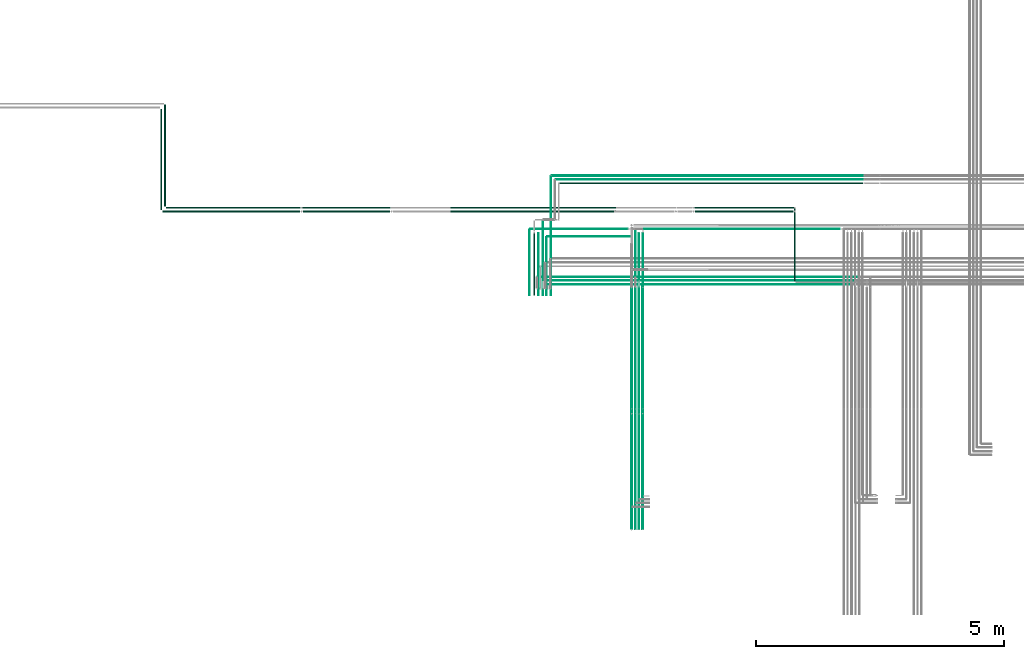
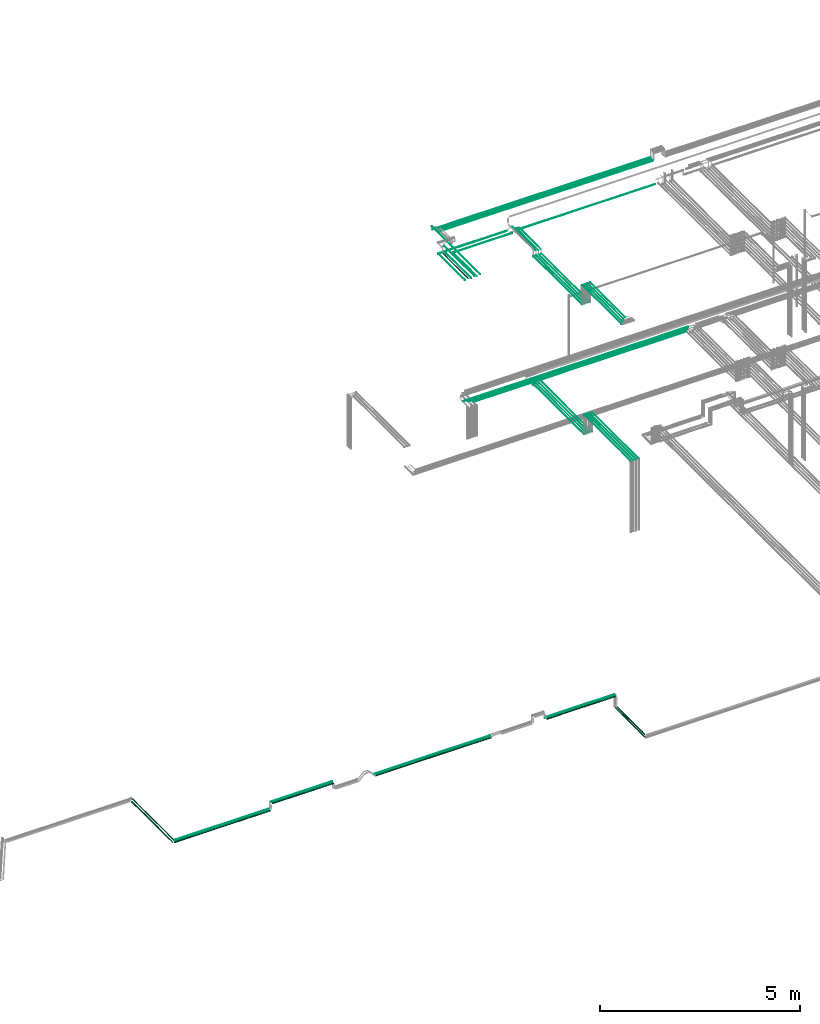
# One storey, part 3 of 331: 49 flow segments.
"""IFC2X3 building model written with IfcOpenShell, lengths in millimetres."""

from ifc_helpers import new_model, entity, si_unit, converted_unit, derived_unit, direction, frame, frame_2d, origin, origin_2d_with_axis, place, context, subcontext, project, spatial, circle, extrude, type_object, element, save


model = new_model("IFC2X3")

# Units and contexts
model_context = context("Model", 3, precision=0.01, world=origin(), true_north=direction((6.12303176911189e-17, 1.0)))
body_context = subcontext(model_context, "Body", "Model", "MODEL_VIEW")
ifc_project = project(units=[si_unit("LENGTHUNIT", "METRE", prefix="MILLI"), si_unit("AREAUNIT", "SQUARE_METRE"), si_unit("VOLUMEUNIT", "CUBIC_METRE"), converted_unit("PLANEANGLEUNIT", "DEGREE", entity("IfcRatioMeasure", 0.0174532925199433), si_unit("PLANEANGLEUNIT", "RADIAN"), dimensions=[0, 0, 0, 0, 0, 0, 0]), si_unit("MASSUNIT", "GRAM", prefix="KILO"), derived_unit("MASSDENSITYUNIT", [(si_unit("MASSUNIT", "GRAM", prefix="KILO"), 1), (si_unit("LENGTHUNIT", "METRE"), -3)]), derived_unit("MOMENTOFINERTIAUNIT", [(si_unit("LENGTHUNIT", "METRE"), 4)]), si_unit("TIMEUNIT", "SECOND"), si_unit("FREQUENCYUNIT", "HERTZ"), si_unit("THERMODYNAMICTEMPERATUREUNIT", "DEGREE_CELSIUS"), derived_unit("THERMALTRANSMITTANCEUNIT", [(si_unit("MASSUNIT", "GRAM", prefix="KILO"), 1), (si_unit("THERMODYNAMICTEMPERATUREUNIT", "KELVIN"), -1), (si_unit("TIMEUNIT", "SECOND"), -3)]), derived_unit("VOLUMETRICFLOWRATEUNIT", [(si_unit("LENGTHUNIT", "METRE"), 3), (si_unit("TIMEUNIT", "SECOND"), -1)]), derived_unit("MASSFLOWRATEUNIT", [(si_unit("MASSUNIT", "GRAM", prefix="KILO"), 1), (si_unit("TIMEUNIT", "SECOND"), -1)]), derived_unit("ROTATIONALFREQUENCYUNIT", [(si_unit("TIMEUNIT", "SECOND"), -1)]), si_unit("ELECTRICCURRENTUNIT", "AMPERE"), si_unit("ELECTRICVOLTAGEUNIT", "VOLT"), si_unit("POWERUNIT", "WATT"), si_unit("FORCEUNIT", "NEWTON", prefix="KILO"), si_unit("ILLUMINANCEUNIT", "LUX"), si_unit("LUMINOUSFLUXUNIT", "LUMEN"), si_unit("LUMINOUSINTENSITYUNIT", "CANDELA"), derived_unit("USERDEFINED", [(si_unit("MASSUNIT", "GRAM", prefix="KILO"), -1), (si_unit("LENGTHUNIT", "METRE"), -2), (si_unit("TIMEUNIT", "SECOND"), 3), (si_unit("LUMINOUSFLUXUNIT", "LUMEN"), 1)]), derived_unit("LINEARVELOCITYUNIT", [(si_unit("LENGTHUNIT", "METRE"), 1), (si_unit("TIMEUNIT", "SECOND"), -1)]), si_unit("PRESSUREUNIT", "PASCAL"), derived_unit("USERDEFINED", [(si_unit("LENGTHUNIT", "METRE"), -2), (si_unit("MASSUNIT", "GRAM", prefix="KILO"), 1), (si_unit("TIMEUNIT", "SECOND"), -2)]), derived_unit("LINEARFORCEUNIT", [(si_unit("MASSUNIT", "GRAM", prefix="KILO"), 1), (si_unit("LENGTHUNIT", "METRE"), 1), (si_unit("TIMEUNIT", "SECOND"), -2), (si_unit("LENGTHUNIT", "METRE"), -1)]), derived_unit("PLANARFORCEUNIT", [(si_unit("MASSUNIT", "GRAM", prefix="KILO"), 1), (si_unit("LENGTHUNIT", "METRE"), 1), (si_unit("TIMEUNIT", "SECOND"), -2), (si_unit("LENGTHUNIT", "METRE"), -2)])], contexts=[model_context])

# Site, building, storey
site_placement = place(None, frame((0.0, -0.00077364408347762, 0.0)))
site = spatial("IfcSite", under=ifc_project, at=site_placement, CompositionType="ELEMENT")
building_placement = place(site_placement, origin())
building = spatial("IfcBuilding", under=site, at=building_placement, CompositionType="ELEMENT")
storey_placement = place(building_placement, origin())
storey = spatial("IfcBuildingStorey", under=building, at=storey_placement, CompositionType="ELEMENT", Elevation=0.0)

# Flow segments
pipe_segment_type = type_object("IfcPipeSegmentType", PredefinedType="NOTDEFINED")
flow_segment_1_placement = place(building_placement, frame((11109.4049963189, 9664.07079577274, 2934.40472776409)))
element("IfcFlowSegment", 1, at=flow_segment_1_placement, inside=storey, type_object=pipe_segment_type, context=body_context, shape_type="SweptSolid", body=[
    extrude(circle(Radius=14.0, at=origin_2d_with_axis()), frame((15.595272235917, 0.0, 15.595272235916), z_axis=(0.0, 1.0, 0.0), x_axis=(1.0, 0.0, 0.0)), (0.0, 0.0, 1.0), 2031.03131897251),
])
flow_segment_2_placement = place(storey_placement, frame((18943.0013832023, 8148.41467161338, 14542.4047277641)))
element("IfcFlowSegment", 2, at=flow_segment_2_placement, inside=storey, type_object=pipe_segment_type, context=body_context, shape_type="SweptSolid", body=[
    extrude(circle(Radius=6.0, at=origin_2d_with_axis()), frame((0.0, 7.59527223591562, 7.5952722359167), z_axis=(1.0, 0.0, 0.0), x_axis=(0.0, 1.0, 0.0)), (0.0, 0.0, 1.0), 1896.10715174612),
])
flow_segment_3_placement = place(storey_placement, frame((18845.0511304109, 8223.41467160421, 14542.4046441965)))
element("IfcFlowSegment", 3, at=flow_segment_3_placement, inside=storey, type_object=pipe_segment_type, context=body_context, shape_type="SweptSolid", body=[
    extrude(circle(Radius=6.0, at=frame_2d((4.61084823655256e-09, 8.04938451892667e-08), x_axis=(1.0, 0.0))), frame((0.0, 7.59527224052538, 7.59527231641055), z_axis=(1.0, 0.0, 0.0), x_axis=(0.0, 1.0, 0.0)), (0.0, 0.0, 1.0), 1919.0574084587),
])
flow_segment_4_placement = place(storey_placement, frame((18729.0511304109, 8296.9146716134, 14540.9031015625)))
element("IfcFlowSegment", 4, at=flow_segment_4_placement, inside=storey, type_object=pipe_segment_type, context=body_context, shape_type="SweptSolid", body=[
    extrude(circle(Radius=7.5, at=frame_2d((1.40772726808791e-11, -2.16573425859679e-12), x_axis=(1.0, 0.0))), frame((0.0, 9.09527223593044, 9.09527223591853), z_axis=(1.0, 0.0, 0.0), x_axis=(0.0, 1.0, 0.0)), (0.0, 0.0, 1.0), 1959.05740012401),
])
flow_segment_5_placement = place(storey_placement, frame((20690.5132627125, 5553.62056382732, 14544.4047277641)))
element("IfcFlowSegment", 5, at=flow_segment_5_placement, inside=storey, type_object=pipe_segment_type, context=body_context, shape_type="SweptSolid", body=[
    extrude(circle(Radius=4.0, at=frame_2d((4.33146851719357e-12, -4.33146851719357e-12), x_axis=(1.0, 0.0))), frame((5.59527223591499, 0.0, 5.59527223590849), z_axis=(0.0, 1.0, 0.0), x_axis=(-1.0, 0.0, 0.0)), (0.0, 0.0, 1.0), 2526.52824282757),
])
flow_segment_6_placement = place(storey_placement, frame((20763.5132627125, 5557.62056382732, 14542.4047277641)))
element("IfcFlowSegment", 6, at=flow_segment_6_placement, inside=storey, type_object=pipe_segment_type, context=body_context, shape_type="SweptSolid", body=[
    extrude(circle(Radius=6.0, at=frame_2d((0.0, -2.16573425859679e-12), x_axis=(1.0, 0.0))), frame((7.59527223591454, 0.0, 7.59527223591454), z_axis=(0.0, 1.0, 0.0), x_axis=(-1.0, 0.0, 0.0)), (0.0, 0.0, 1.0), 2516.52824282755),
])
flow_segment_7_placement = place(storey_placement, frame((20838.5132627125, 5557.62056382732, 14542.4047277641)))
element("IfcFlowSegment", 7, at=flow_segment_7_placement, inside=storey, type_object=pipe_segment_type, context=body_context, shape_type="SweptSolid", body=[
    extrude(circle(Radius=6.0, at=frame_2d((-4.33146851719357e-12, 0.0), x_axis=(1.0, 0.0))), frame((7.59527223591454, 0.0, 7.5952722359167), z_axis=(0.0, 1.0, 0.0), x_axis=(-1.0, 0.0, 0.0)), (0.0, 0.0, 1.0), 2591.38938002198),
])
flow_segment_8_placement = place(storey_placement, frame((20853.1085349484, 8148.41467161332, 14542.4047277641)))
element("IfcFlowSegment", 8, at=flow_segment_8_placement, inside=storey, type_object=pipe_segment_type, context=body_context, shape_type="SweptSolid", body=[
    extrude(circle(Radius=6.0, at=frame_2d((-3.0320279620355e-11, 0.0), x_axis=(1.0, 0.0))), frame((0.0, 7.59527223594594, 7.5952722359167), z_axis=(1.0, 0.0, 0.0), x_axis=(0.0, 1.0, 0.0)), (0.0, 0.0, 1.0), 4211.00000363575),
])
flow_segment_9_placement = place(storey_placement, frame((20612.0132627125, 5561.62056382732, 14540.9047277641)))
element("IfcFlowSegment", 9, at=flow_segment_9_placement, inside=storey, type_object=pipe_segment_type, context=body_context, shape_type="SweptSolid", body=[
    extrude(circle(Radius=7.5, at=frame_2d((0.0, -2.16573425859679e-12), x_axis=(1.0, 0.0))), frame((9.09527223591419, 0.0, 9.09527223591853), z_axis=(0.0, 1.0, 0.0), x_axis=(-1.0, 0.0, 0.0)), (0.0, 0.0, 1.0), 2510.52824282756),
])
for number, where in (
    (10, (20838.5132627125, 3217.62056382732, 15142.4047277641)),
    (11, (20763.5132627125, 3217.62056382732, 15142.4047277641)),
):
    element("IfcFlowSegment", number, at=place(storey_placement, frame(where)), inside=storey, type_object=pipe_segment_type, context=body_context, shape_type="SweptSolid", body=[
        extrude(circle(Radius=6.0, at=origin_2d_with_axis()), frame((7.59527223591454, 0.0, 7.5952722359167), z_axis=(0.0, 1.0, 0.0), x_axis=(-1.0, 0.0, 0.0)), (0.0, 0.0, 1.0), 2312.0),
    ])
flow_segment_10_placement = place(storey_placement, frame((20690.5132627125, 3213.62056382732, 15144.4047277641)))
element("IfcFlowSegment", 12, at=flow_segment_10_placement, inside=storey, type_object=pipe_segment_type, context=body_context, shape_type="SweptSolid", body=[
    extrude(circle(Radius=4.0, at=origin_2d_with_axis()), frame((5.59527223591499, 0.0, 5.59527223591499), z_axis=(0.0, 1.0, 0.0), x_axis=(-1.0, 0.0, 0.0)), (0.0, 0.0, 1.0), 2320.0),
])
flow_segment_11_placement = place(storey_placement, frame((20612.0132627125, 3221.62056382732, 15140.9047277641)))
element("IfcFlowSegment", 13, at=flow_segment_11_placement, inside=storey, type_object=pipe_segment_type, context=body_context, shape_type="SweptSolid", body=[
    extrude(circle(Radius=7.5, at=frame_2d((0.0, 2.16573425859679e-12), x_axis=(1.0, 0.0))), frame((9.09527223591419, 0.0, 9.09527223591419), z_axis=(0.0, 1.0, 0.0), x_axis=(-1.0, 0.0, 0.0)), (0.0, 0.0, 1.0), 2304.0),
])
flow_segment_12_placement = place(storey_placement, frame((20778.1085388696, 8223.41467161343, 14542.4044535826)))
element("IfcFlowSegment", 14, at=flow_segment_12_placement, inside=storey, type_object=pipe_segment_type, context=body_context, shape_type="SweptSolid", body=[
    extrude(circle(Radius=6.0, at=frame_2d((-1.08286712929839e-12, 0.0), x_axis=(1.0, 0.0))), frame((0.0, 7.5952722359167, 7.5952722359167), z_axis=(1.0, 0.0, 0.0), x_axis=(0.0, 1.0, 0.0)), (0.0, 0.0, 1.0), 4361.00000363574),
])
flow_segment_13_placement = place(storey_placement, frame((20704.1085305349, 8296.91467161342, 14540.9033337887)))
element("IfcFlowSegment", 15, at=flow_segment_13_placement, inside=storey, type_object=pipe_segment_type, context=body_context, shape_type="SweptSolid", body=[
    extrude(circle(Radius=7.5, at=frame_2d((-1.08286712929839e-12, 7.78132442118943e-31), x_axis=(1.0, 0.0))), frame((0.0, 9.09527223591744, 9.09527223591636), z_axis=(1.0, 0.0, 0.0), x_axis=(0.0, 1.0, 0.0)), (0.0, 0.0, 1.0), 4509.00000363573),
])
flow_segment_14_placement = place(building_placement, frame((11187.4049963189, 9729.07029214865, 2937.40472776407)))
element("IfcFlowSegment", 16, at=flow_segment_14_placement, inside=storey, type_object=pipe_segment_type, context=body_context, shape_type="SweptSolid", body=[
    extrude(circle(Radius=11.0, at=origin_2d_with_axis()), frame((12.5952722359156, 0.0, 12.5952722359161), z_axis=(0.0, 1.0, 0.0), x_axis=(-1.0, 0.0, 0.0)), (0.0, 0.0, 1.0), 2051.0318225966),
])
flow_segment_15_placement = place(storey_placement, frame((20840.733655358, 5653.62056382736, 18444.404727764)))
element("IfcFlowSegment", 17, at=flow_segment_15_placement, inside=storey, type_object=pipe_segment_type, context=body_context, shape_type="SweptSolid", body=[
    extrude(circle(Radius=4.0, at=frame_2d((4.33146851719357e-12, 0.0), x_axis=(1.0, 0.0))), frame((5.59527223591932, 0.0, 5.59527223591499), z_axis=(0.0, 1.0, 0.0), x_axis=(-1.0, 0.0, 0.0)), (0.0, 0.0, 1.0), 2426.52824282752),
])
flow_segment_16_placement = place(storey_placement, frame((20765.7336553581, 8100.14880665486, 18564.404727764)))
element("IfcFlowSegment", 18, at=flow_segment_16_placement, inside=storey, type_object=pipe_segment_type, context=body_context, shape_type="SweptSolid", body=[
    extrude(circle(Radius=4.0, at=origin_2d_with_axis()), frame((5.59527223591066, 0.0, 5.59527223591499), z_axis=(0.0, 1.0, 0.0), x_axis=(1.0, 0.0, 0.0)), (0.0, 0.0, 1.0), 1089.85119334521),
])
flow_segment_17_placement = place(storey_placement, frame((20765.733655358, 5653.62056382736, 18444.404727764)))
element("IfcFlowSegment", 19, at=flow_segment_17_placement, inside=storey, type_object=pipe_segment_type, context=body_context, shape_type="SweptSolid", body=[
    extrude(circle(Radius=4.0, at=origin_2d_with_axis()), frame((5.59527223591499, 0.0, 5.59527223591499), z_axis=(0.0, 1.0, 0.0), x_axis=(-1.0, 0.0, 0.0)), (0.0, 0.0, 1.0), 2426.52824282751),
])
flow_segment_18_placement = place(storey_placement, frame((20688.733655358, 8104.14880665486, 18592.404727764)))
element("IfcFlowSegment", 20, at=flow_segment_18_placement, inside=storey, type_object=pipe_segment_type, context=body_context, shape_type="SweptSolid", body=[
    extrude(circle(Radius=6.0, at=frame_2d((0.0, 2.16573425859679e-12), x_axis=(1.0, 0.0))), frame((7.59527223591454, 0.0, 7.59527223591887), z_axis=(0.0, 1.0, 0.0), x_axis=(1.0, 0.0, 0.0)), (0.0, 0.0, 1.0), 1156.85119334551),
])
flow_segment_19_placement = place(storey_placement, frame((20688.733655358, 5657.62056382738, 18442.404727764)))
element("IfcFlowSegment", 21, at=flow_segment_19_placement, inside=storey, type_object=pipe_segment_type, context=body_context, shape_type="SweptSolid", body=[
    extrude(circle(Radius=6.0, at=origin_2d_with_axis()), frame((7.59527223591454, 0.0, 7.5952722359167), z_axis=(0.0, 1.0, 0.0), x_axis=(-1.0, 0.0, 0.0)), (0.0, 0.0, 1.0), 2418.52824282749),
])
flow_segment_20_placement = place(storey_placement, frame((20688.7336553581, 3755.48876707971, 19042.4047277641)))
element("IfcFlowSegment", 22, at=flow_segment_20_placement, inside=storey, type_object=pipe_segment_type, context=body_context, shape_type="SweptSolid", body=[
    extrude(circle(Radius=6.0, at=origin_2d_with_axis()), frame((7.59527223591454, 0.0, 7.5952722359167), z_axis=(0.0, 1.0, 0.0), x_axis=(1.0, 0.0, 0.0)), (0.0, 0.0, 1.0), 1874.13179674766),
])
flow_segment_21_placement = place(storey_placement, frame((20765.733655358, 3826.48876707971, 19044.4047277641)))
element("IfcFlowSegment", 23, at=flow_segment_21_placement, inside=storey, type_object=pipe_segment_type, context=body_context, shape_type="SweptSolid", body=[
    extrude(circle(Radius=4.0, at=origin_2d_with_axis()), frame((5.59527223591499, 0.0, 5.59527223591499), z_axis=(0.0, 1.0, 0.0), x_axis=(1.0, 0.0, 0.0)), (0.0, 0.0, 1.0), 1807.13179674766),
])
flow_segment_22_placement = place(storey_placement, frame((20840.733655358, 3896.4887670797, 19044.4047277641)))
element("IfcFlowSegment", 24, at=flow_segment_22_placement, inside=storey, type_object=pipe_segment_type, context=body_context, shape_type="SweptSolid", body=[
    extrude(circle(Radius=4.0, at=origin_2d_with_axis()), frame((5.59527223591499, 0.0, 5.59527223591499), z_axis=(0.0, 1.0, 0.0), x_axis=(1.0, 0.0, 0.0)), (0.0, 0.0, 1.0), 1737.13179674767),
])
flow_segment_23_placement = place(storey_placement, frame((20612.233655358, 5661.62056382737, 18440.9047277641)))
element("IfcFlowSegment", 25, at=flow_segment_23_placement, inside=storey, type_object=pipe_segment_type, context=body_context, shape_type="SweptSolid", body=[
    extrude(circle(Radius=7.5, at=origin_2d_with_axis()), frame((9.09527223591419, 0.0, 9.09527223591636), z_axis=(0.0, 1.0, 0.0), x_axis=(-1.0, 0.0, 0.0)), (0.0, 0.0, 1.0), 2410.52824282749),
])
flow_segment_24_placement = place(storey_placement, frame((20612.233655358, 3681.62056382736, 19040.9047277641)))
element("IfcFlowSegment", 26, at=flow_segment_24_placement, inside=storey, type_object=pipe_segment_type, context=body_context, shape_type="SweptSolid", body=[
    extrude(circle(Radius=7.5, at=origin_2d_with_axis()), frame((9.09527223591419, 0.0, 9.09527223591636), z_axis=(0.0, 1.0, 0.0), x_axis=(-1.0, 0.0, 0.0)), (0.0, 0.0, 1.0), 1944.00000000001),
])
flow_segment_25_placement = place(storey_placement, frame((18896.4558820861, 7939.81073448227, 18517.4047277641)))
element("IfcFlowSegment", 27, at=flow_segment_25_placement, inside=storey, type_object=pipe_segment_type, context=body_context, shape_type="SweptSolid", body=[
    extrude(circle(Radius=6.0, at=frame_2d((4.33146851719357e-12, -1.94916083273711e-11), x_axis=(1.0, 0.0))), frame((7.59527223592103, 0.0, 7.59527223590154), z_axis=(0.0, 1.0, 0.0), x_axis=(-1.0, 0.0, 0.0)), (0.0, 0.0, 1.0), 1171.1892655178),
])
flow_segment_26_placement = place(storey_placement, frame((18733.4518462125, 7939.81073448226, 18517.4047277641)))
element("IfcFlowSegment", 28, at=flow_segment_26_placement, inside=storey, type_object=pipe_segment_type, context=body_context, shape_type="SweptSolid", body=[
    extrude(circle(Radius=6.0, at=frame_2d((2.16573425859679e-12, -1.08286712929839e-11), x_axis=(1.0, 0.0))), frame((7.59527223591887, 0.0, 7.59527223590804), z_axis=(0.0, 1.0, 0.0), x_axis=(-1.0, 0.0, 0.0)), (0.0, 0.0, 1.0), 1246.18926551783),
])
flow_segment_27_placement = place(storey_placement, frame((18551.9518462125, 7939.81073448226, 18515.9047277642)))
element("IfcFlowSegment", 29, at=flow_segment_27_placement, inside=storey, type_object=pipe_segment_type, context=body_context, shape_type="SweptSolid", body=[
    extrude(circle(Radius=7.5, at=frame_2d((2.16573425859679e-12, -1.08286712929839e-11), x_axis=(1.0, 0.0))), frame((9.09527223591636, 0.0, 9.0952722359077), z_axis=(0.0, 1.0, 0.0), x_axis=(-1.0, 0.0, 0.0)), (0.0, 0.0, 1.0), 1317.18926551787),
])
flow_segment_28_placement = place(storey_placement, frame((18988.4518462125, 7939.81073448226, 18547.404727764)))
element("IfcFlowSegment", 30, at=flow_segment_28_placement, inside=storey, type_object=pipe_segment_type, context=body_context, shape_type="SweptSolid", body=[
    extrude(circle(Radius=6.0, at=frame_2d((6.49720277579036e-12, 0.0), x_axis=(1.0, 0.0))), frame((7.5952722359232, 0.0, 7.5952722359167), z_axis=(0.0, 1.0, 0.0), x_axis=(-1.0, 0.0, 0.0)), (0.0, 0.0, 1.0), 2396.21477403165),
])
flow_segment_29_placement = place(storey_placement, frame((18824.2932984618, 7939.81073448227, 18547.404727764)))
element("IfcFlowSegment", 31, at=flow_segment_29_placement, inside=storey, type_object=pipe_segment_type, context=body_context, shape_type="SweptSolid", body=[
    extrude(circle(Radius=6.0, at=frame_2d((-4.33146851719357e-12, 0.0), x_axis=(1.0, 0.0))), frame((7.5952722359167, 0.0, 7.5952722359167), z_axis=(0.0, 1.0, 0.0), x_axis=(-1.0, 0.0, 0.0)), (0.0, 0.0, 1.0), 1506.18926552204),
])
flow_segment_30_placement = place(storey_placement, frame((18639.9437531701, 7939.81073448227, 18542.404727764)))
element("IfcFlowSegment", 32, at=flow_segment_30_placement, inside=storey, type_object=pipe_segment_type, context=body_context, shape_type="SweptSolid", body=[
    extrude(circle(Radius=11.0, at=frame_2d((-2.16573425859679e-12, -2.16573425859679e-12), x_axis=(1.0, 0.0))), frame((12.5952722359177, 0.0, 12.5952722359177), z_axis=(0.0, 1.0, 0.0), x_axis=(-1.0, 0.0, 0.0)), (0.0, 0.0, 1.0), 1236.18926552204),
])
flow_segment_31_placement = place(storey_placement, frame((20840.733655358, 8100.14880665486, 18564.4047277641)))
element("IfcFlowSegment", 33, at=flow_segment_31_placement, inside=storey, type_object=pipe_segment_type, context=body_context, shape_type="SweptSolid", body=[
    extrude(circle(Radius=4.0, at=origin_2d_with_axis()), frame((5.59527223591066, 0.0, 5.59527223591499), z_axis=(0.0, 1.0, 0.0), x_axis=(1.0, 0.0, 0.0)), (0.0, 0.0, 1.0), 1089.85119334514),
])
flow_segment_32_placement = place(storey_placement, frame((18918.051154322, 9117.40472776408, 18517.4047277641)))
element("IfcFlowSegment", 34, at=flow_segment_32_placement, inside=storey, type_object=pipe_segment_type, context=body_context, shape_type="SweptSolid", body=[
    extrude(circle(Radius=6.0, at=origin_2d_with_axis()), frame((0.0, 7.59527223598925, 7.5952722359167), z_axis=(1.0, 0.0, 0.0), x_axis=(0.0, -1.0, 0.0)), (0.0, 0.0, 1.0), 1689.27777327199),
])
flow_segment_33_placement = place(storey_placement, frame((19010.0471184484, 10342.430236278, 18442.4047277641)))
element("IfcFlowSegment", 35, at=flow_segment_33_placement, inside=storey, type_object=pipe_segment_type, context=body_context, shape_type="SweptSolid", body=[
    extrude(circle(Radius=6.0, at=origin_2d_with_axis()), frame((0.0, 7.59527223597301, 7.5952722359167), z_axis=(1.0, 0.0, 0.0), x_axis=(0.0, -1.0, 0.0)), (0.0, 0.0, 1.0), 6290.29178844423),
])
flow_segment_34_placement = place(storey_placement, frame((19085.0471184484, 10267.430236278, 18442.4047277641)))
element("IfcFlowSegment", 36, at=flow_segment_34_placement, inside=storey, type_object=pipe_segment_type, context=body_context, shape_type="SweptSolid", body=[
    extrude(circle(Radius=6.0, at=frame_2d((-1.08286712929839e-11, 0.0), x_axis=(1.0, 0.0))), frame((0.0, 7.5952722359297, 7.5952722359167), z_axis=(1.0, 0.0, 0.0), x_axis=(0.0, 1.0, 0.0)), (0.0, 0.0, 1.0), 6215.29178844421),
])
flow_segment_35_placement = place(storey_placement, frame((19170.0471184484, 10187.430236278, 18437.4047277641)))
element("IfcFlowSegment", 37, at=flow_segment_35_placement, inside=storey, type_object=pipe_segment_type, context=body_context, shape_type="SweptSolid", body=[
    extrude(circle(Radius=11.0, at=frame_2d((-1.08286712929839e-11, 0.0), x_axis=(1.0, 0.0))), frame((0.0, 12.5952722359264, 12.5952722359156), z_axis=(1.0, 0.0, 0.0), x_axis=(0.0, 1.0, 0.0)), (0.0, 0.0, 1.0), 6120.29178844422),
])
flow_segment_36_placement = place(storey_placement, frame((20853.328927594, 9267.40472776407, 18442.4047277641)))
element("IfcFlowSegment", 38, at=flow_segment_36_placement, inside=storey, type_object=pipe_segment_type, context=body_context, shape_type="SweptSolid", body=[
    extrude(circle(Radius=6.0, at=frame_2d((3.24860138789518e-12, 0.0), x_axis=(1.0, 0.0))), frame((0.0, 7.59527223592103, 7.5952722359167), z_axis=(1.0, 0.0, 0.0), x_axis=(0.0, 1.0, 0.0)), (0.0, 0.0, 1.0), 3967.00997929867),
])
flow_segment_37_placement = place(storey_placement, frame((18579.0471184484, 9265.90472776421, 18515.9047277642)))
element("IfcFlowSegment", 39, at=flow_segment_37_placement, inside=storey, type_object=pipe_segment_type, context=body_context, shape_type="SweptSolid", body=[
    extrude(circle(Radius=7.5, at=origin_2d_with_axis()), frame((0.0, 9.09527223591636, 9.09527223591636), z_axis=(1.0, 0.0, 0.0), x_axis=(0.0, 1.0, 0.0)), (0.0, 0.0, 1.0), 1961.28180914507),
])
flow_segment_38_placement = place(building_placement, frame((11224.0002685548, 9692.47501991274, 2937.40472776411)))
element("IfcFlowSegment", 40, at=flow_segment_38_placement, inside=storey, type_object=pipe_segment_type, context=body_context, shape_type="SweptSolid", body=[
    extrude(circle(Radius=11.0, at=frame_2d((7.58006990508875e-12, 0.0), x_axis=(1.0, 0.0))), frame((0.0, 12.595272235921, 12.5952722359161), z_axis=(1.0, 0.0, 0.0), x_axis=(0.0, 1.0, 0.0)), (0.0, 0.0, 1.0), 2710.71489158505),
])
flow_segment_39_placement = place(building_placement, frame((23901.8903796085, 8219.51626169267, 2537.40472776408)))
element("IfcFlowSegment", 41, at=flow_segment_39_placement, inside=storey, type_object=pipe_segment_type, context=body_context, shape_type="SweptSolid", body=[
    extrude(circle(Radius=11.0, at=origin_2d_with_axis()), frame((12.5952722359177, 0.0, 12.5952722359161), z_axis=(0.0, 1.0, 0.0), x_axis=(1.0, 0.0, 0.0)), (0.0, 0.0, 1.0), 1461.554030456),
])
flow_segment_40_placement = place(building_placement, frame((23898.8903796085, 8229.51626169267, 2609.40472776408)))
element("IfcFlowSegment", 42, at=flow_segment_40_placement, inside=storey, type_object=pipe_segment_type, context=body_context, shape_type="SweptSolid", body=[
    extrude(circle(Radius=14.0, at=origin_2d_with_axis()), frame((15.595272235917, 0.0, 15.595272235916), z_axis=(0.0, 1.0, 0.0), x_axis=(1.0, 0.0, 0.0)), (0.0, 0.0, 1.0), 1366.55403045585),
])
flow_segment_41_placement = place(building_placement, frame((21893.5453539384, 9692.47501991275, 2937.40472776409)))
element("IfcFlowSegment", 43, at=flow_segment_41_placement, inside=storey, type_object=pipe_segment_type, context=body_context, shape_type="SweptSolid", body=[
    extrude(circle(Radius=11.0, at=frame_2d((-1.08286712929839e-12, 0.0), x_axis=(1.0, 0.0))), frame((0.0, 12.5952722359166, 12.5952722359161), z_axis=(1.0, 0.0, 0.0), x_axis=(0.0, 1.0, 0.0)), (0.0, 0.0, 1.0), 1996.940297906),
])
flow_segment_42_placement = place(building_placement, frame((21903.5453539384, 9614.4750199126, 2934.40472776411)))
element("IfcFlowSegment", 44, at=flow_segment_42_placement, inside=storey, type_object=pipe_segment_type, context=body_context, shape_type="SweptSolid", body=[
    extrude(circle(Radius=14.0, at=frame_2d((-1.08286712929839e-12, 0.0), x_axis=(1.0, 0.0))), frame((0.0, 15.595272235917, 15.595272235916), z_axis=(1.0, 0.0, 0.0), x_axis=(0.0, 1.0, 0.0)), (0.0, 0.0, 1.0), 1976.94029790598),
])
flow_segment_43_placement = place(building_placement, frame((16969.903751033, 9614.39842868039, 2934.40472776409)))
element("IfcFlowSegment", 45, at=flow_segment_43_placement, inside=storey, type_object=pipe_segment_type, context=body_context, shape_type="SweptSolid", body=[
    extrude(circle(Radius=14.0, at=origin_2d_with_axis()), frame((0.000334024404321553, 15.595272231931, 15.595272235916), z_axis=(1.0, 2.38588859712468e-05, 0.0), x_axis=(2.38588859712468e-05, -1.0, 0.0)), (0.0, 0.0, 1.0), 3317.30999863646),
])
flow_segment_44_placement = place(building_placement, frame((16968.9040850575, 9692.47501991276, 2937.40472776405)))
element("IfcFlowSegment", 46, at=flow_segment_44_placement, inside=storey, type_object=pipe_segment_type, context=body_context, shape_type="SweptSolid", body=[
    extrude(circle(Radius=11.0, at=frame_2d((1.08286712929839e-12, 0.0), x_axis=(1.0, 0.0))), frame((0.0, 12.5952722359145, 12.5952722359161), z_axis=(1.0, 0.0, 0.0), x_axis=(0.0, 1.0, 0.0)), (0.0, 0.0, 1.0), 3331.30999775656),
])
flow_segment_45_placement = place(building_placement, frame((13992.7151005605, 9614.40702490668, 3129.40472776511)))
element("IfcFlowSegment", 47, at=flow_segment_45_placement, inside=storey, type_object=pipe_segment_type, context=body_context, shape_type="SweptSolid", body=[
    extrude(circle(Radius=14.0, at=origin_2d_with_axis()), frame((5.95788881526005e-05, 15.6027122846073, 15.595272235916), z_axis=(1.0, -4.25563485897267e-06, 0.0), x_axis=(4.25563485897267e-06, 1.0, 0.0)), (0.0, 0.0, 1.0), 1748.28176370492),
])
flow_segment_46_placement = place(building_placement, frame((13982.7151601398, 9692.47501991275, 3132.40472776409)))
element("IfcFlowSegment", 48, at=flow_segment_46_placement, inside=storey, type_object=pipe_segment_type, context=body_context, shape_type="SweptSolid", body=[
    extrude(circle(Radius=11.0, at=origin_2d_with_axis()), frame((0.0, 12.5952722359242, 12.5952722359161), z_axis=(1.0, 0.0, 0.0), x_axis=(0.0, -1.0, 0.0)), (0.0, 0.0, 1.0), 1768.28176368837),
])
flow_segment_47_placement = place(building_placement, frame((11158.999967088, 9614.4152978242, 2934.40472756609)))
element("IfcFlowSegment", 49, at=flow_segment_47_placement, inside=storey, type_object=pipe_segment_type, context=body_context, shape_type="SweptSolid", body=[
    extrude(circle(Radius=14.0, at=origin_2d_with_axis()), frame((0.000301460120806496, 15.6548260000449, 15.595272235916), z_axis=(1.0, -2.1532865712728e-05, 0.0), x_axis=(2.1532865712728e-05, 1.0, 0.0)), (0.0, 0.0, 1.0), 2765.71489223951),
])

save(model, "model.ifc")
